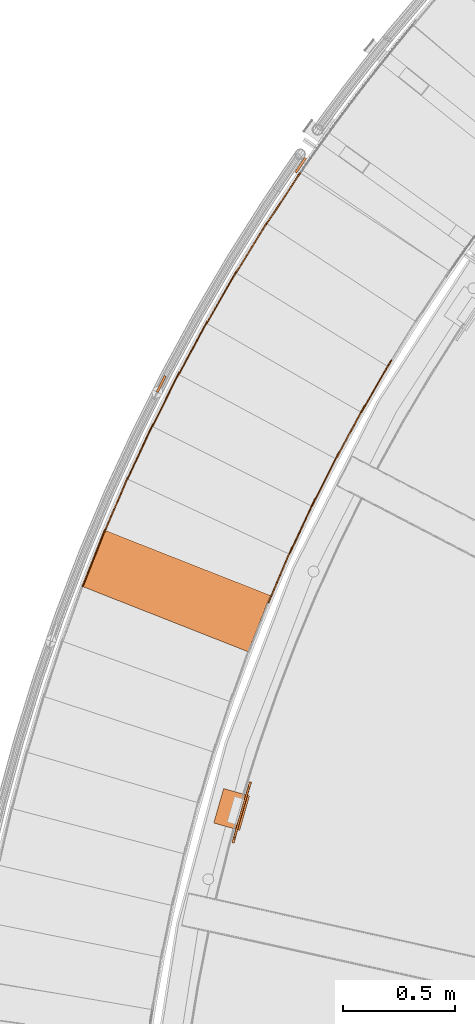
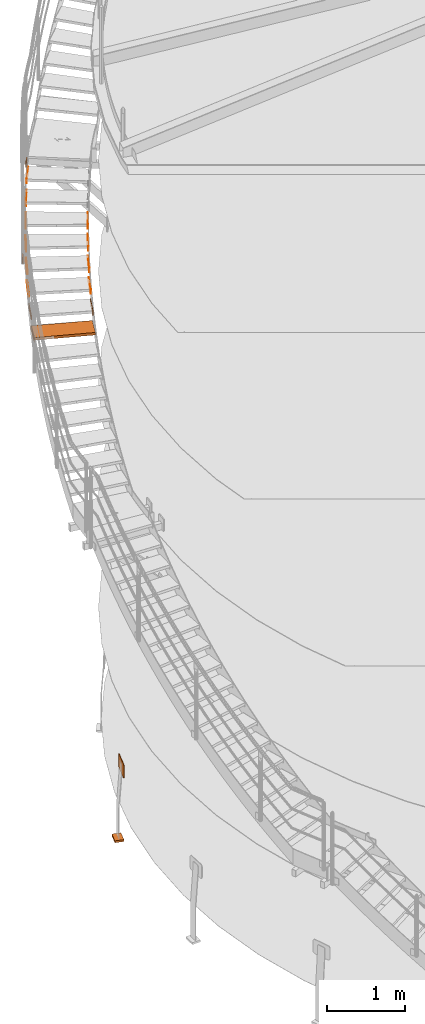
# One storey, part 62 of 126: 18 proxies.
"""IFC2X3 building model written with IfcOpenShell, lengths in millimetres."""

from ifc_helpers import new_model, si_unit, origin, origin_with_axes, place, context, project, spatial, faceted_brep, material, element, save


model = new_model("IFC2X3")

# Units and contexts
context_of_model_1 = context(None, 3, precision=0.1, world=origin())
context_of_model_2 = context(None, 3, precision=0.1, world=origin())
ifc_project = project(units=[si_unit("LENGTHUNIT", "METRE", prefix="MILLI"), si_unit("AREAUNIT", "SQUARE_METRE", prefix="CENTI"), si_unit("VOLUMEUNIT", "CUBIC_METRE", prefix="CENTI"), si_unit("MASSUNIT", "GRAM", prefix="KILO")], contexts=[context_of_model_1, context_of_model_2])

# Site, building, storey
site_placement = place(None, origin_with_axes())
site = spatial("IfcSite", under=ifc_project, at=site_placement, CompositionType="ELEMENT")
building_placement = place(site_placement, origin_with_axes())
building = spatial("IfcBuilding", under=site, at=building_placement, CompositionType="ELEMENT")
storey_placement = place(building_placement, origin_with_axes())
storey = spatial("IfcBuildingStorey", under=building, at=storey_placement, CompositionType="ELEMENT")

# Proxies
ifc_material_1 = material(Name="S235JRG2")
proxy_1_placement = place(storey_placement, origin_with_axes())
element("IfcBuildingElementProxy", 1, at=proxy_1_placement, inside=storey, material=ifc_material_1, context=context_of_model_2, shape_type="Brep", body=[
    faceted_brep([(-220.6481, 11165.666, 6887.93), (-220.6481, 11165.666, 6927.93), (-121.7076, 11416.884, 6927.93), (-121.7076, 11416.884, 6887.93), (514.399, 10876.173, 6887.93), (613.3394, 11127.392, 6887.93), (613.3394, 11127.392, 6927.93), (514.399, 10876.173, 6927.93)], [[[0, 1, 2, 3]], [[4, 5, 6, 7]], [[0, 4, 7, 1]], [[1, 7, 6, 2]], [[2, 6, 5, 3]], [[3, 5, 4, 0]]]),
])
proxy_2_placement = place(storey_placement, origin_with_axes())
element("IfcBuildingElementProxy", 2, at=proxy_2_placement, inside=storey, material=ifc_material_1, context=context_of_model_2, shape_type="Brep", body=[
    faceted_brep([(-225.3003, 11167.498, 6857.93), (-220.6481, 11165.666, 6857.93), (-220.6481, 11165.666, 6927.93), (-225.3003, 11167.498, 6927.93), (-126.3598, 11418.716, 6927.93), (-121.7076, 11416.884, 6927.93), (-121.7076, 11416.884, 6887.93), (-126.3598, 11418.716, 6887.93), (-137.3532, 11390.803, 6857.93), (-132.701, 11388.971, 6857.93)], [[[0, 1, 2, 3]], [[4, 5, 6, 7]], [[0, 8, 9, 1]], [[1, 9, 6, 5, 2]], [[2, 5, 4, 3]], [[0, 3, 4, 7, 8]], [[6, 9, 8, 7]]]),
])
proxy_3_placement = place(storey_placement, origin_with_axes())
element("IfcBuildingElementProxy", 3, at=proxy_3_placement, inside=storey, material=ifc_material_1, context=context_of_model_2, shape_type="Brep", body=[
    faceted_brep([(602.1531, 11095.404, 7031.09), (606.7493, 11093.436, 7031.09), (606.7493, 11093.436, 7101.09), (602.1531, 11095.404, 7101.09), (708.4449, 11343.602, 7101.09), (713.0411, 11341.633, 7101.09), (713.0411, 11341.633, 7061.09), (708.4449, 11343.602, 7061.09), (696.6347, 11316.024, 7031.09), (701.2309, 11314.056, 7031.09)], [[[0, 1, 2, 3]], [[4, 5, 6, 7]], [[0, 8, 9, 1]], [[1, 9, 6, 5, 2]], [[2, 5, 4, 3]], [[0, 3, 4, 7, 8]], [[6, 9, 8, 7]]]),
])
proxy_4_placement = place(storey_placement, origin_with_axes())
element("IfcBuildingElementProxy", 4, at=proxy_4_placement, inside=storey, material=ifc_material_1, context=context_of_model_2, shape_type="Brep", body=[
    faceted_brep([(-128.651, 11408.374, 7031.09), (-124.0547, 11406.406, 7031.09), (-124.0547, 11406.406, 7101.09), (-128.651, 11408.374, 7101.09), (-22.3591, 11656.572, 7101.09), (-17.7629, 11654.603, 7101.09), (-17.7629, 11654.603, 7061.09), (-22.3591, 11656.572, 7061.09), (-34.1693, 11628.994, 7031.09), (-29.5731, 11627.026, 7031.09)], [[[0, 1, 2, 3]], [[4, 5, 6, 7]], [[0, 8, 9, 1]], [[1, 9, 6, 5, 2]], [[2, 5, 4, 3]], [[0, 3, 4, 7, 8]], [[6, 9, 8, 7]]]),
])
proxy_5_placement = place(storey_placement, origin_with_axes())
element("IfcBuildingElementProxy", 5, at=proxy_5_placement, inside=storey, material=ifc_material_1, context=context_of_model_2, shape_type="Brep", body=[
    faceted_brep([(696.3219, 11311.957, 7204.25), (700.8582, 11309.854, 7204.25), (700.8582, 11309.854, 7274.25), (696.3219, 11311.957, 7274.25), (809.873, 11556.918, 7274.25), (814.4093, 11554.816, 7274.25), (814.4093, 11554.816, 7234.25), (809.873, 11556.918, 7234.25), (797.2562, 11529.7, 7204.25), (801.7925, 11527.598, 7204.25)], [[[0, 1, 2, 3]], [[4, 5, 6, 7]], [[0, 8, 9, 1]], [[1, 9, 6, 5, 2]], [[2, 5, 4, 3]], [[0, 3, 4, 7, 8]], [[6, 9, 8, 7]]]),
])
proxy_6_placement = place(storey_placement, origin_with_axes())
element("IfcBuildingElementProxy", 6, at=proxy_6_placement, inside=storey, material=ifc_material_1, context=context_of_model_2, shape_type="Brep", body=[
    faceted_brep([(-24.9537, 11646.302, 7204.25), (-20.4174, 11644.199, 7204.25), (-20.4174, 11644.199, 7274.25), (-24.9537, 11646.302, 7274.25), (88.5974, 11891.263, 7274.25), (93.1337, 11889.16, 7274.25), (93.1337, 11889.16, 7234.25), (88.5974, 11891.263, 7234.25), (75.9806, 11864.045, 7204.25), (80.5169, 11861.942, 7204.25)], [[[0, 1, 2, 3]], [[4, 5, 6, 7]], [[0, 8, 9, 1]], [[1, 9, 6, 5, 2]], [[2, 5, 4, 3]], [[0, 3, 4, 7, 8]], [[6, 9, 8, 7]]]),
])
proxy_7_placement = place(storey_placement, origin_with_axes())
element("IfcBuildingElementProxy", 7, at=proxy_7_placement, inside=storey, material=ifc_material_1, context=context_of_model_2, shape_type="Brep", body=[
    faceted_brep([(796.8238, 11525.644, 7377.41), (801.2963, 11523.409, 7377.41), (801.2963, 11523.409, 7447.41), (796.8238, 11525.644, 7447.41), (917.5358, 11767.157, 7447.41), (922.0083, 11764.922, 7447.41), (922.0083, 11764.922, 7407.41), (917.5358, 11767.157, 7407.41), (904.1234, 11740.323, 7377.41), (908.5958, 11738.087, 7377.41)], [[[0, 1, 2, 3]], [[4, 5, 6, 7]], [[0, 8, 9, 1]], [[1, 9, 6, 5, 2]], [[2, 5, 4, 3]], [[0, 3, 4, 7, 8]], [[6, 9, 8, 7]]]),
])
proxy_8_placement = place(storey_placement, origin_with_axes())
element("IfcBuildingElementProxy", 8, at=proxy_8_placement, inside=storey, material=ifc_material_1, context=context_of_model_2, shape_type="Brep", body=[
    faceted_brep([(85.7017, 11881.074, 7377.41), (90.1741, 11878.839, 7377.41), (90.1741, 11878.839, 7447.41), (85.7017, 11881.074, 7447.41), (206.4137, 12122.587, 7447.41), (210.8861, 12120.352, 7447.41), (210.8861, 12120.352, 7407.41), (206.4137, 12122.587, 7407.41), (193.0012, 12095.752, 7377.41), (197.4737, 12093.517, 7377.41)], [[[0, 1, 2, 3]], [[4, 5, 6, 7]], [[0, 8, 9, 1]], [[1, 9, 6, 5, 2]], [[2, 5, 4, 3]], [[0, 3, 4, 7, 8]], [[6, 9, 8, 7]]]),
])
proxy_9_placement = place(storey_placement, origin_with_axes())
element("IfcBuildingElementProxy", 9, at=proxy_9_placement, inside=storey, material=ifc_material_1, context=context_of_model_2, shape_type="Brep", body=[
    faceted_brep([(903.5718, 11736.281, 7550.57), (907.9765, 11733.915, 7550.57), (907.9765, 11733.915, 7620.57), (903.5718, 11736.281, 7620.57), (1031.34, 11974.136, 7620.57), (1035.7448, 11971.77, 7620.57), (1035.7448, 11971.77, 7580.57), (1031.34, 11974.136, 7580.57), (1017.1436, 11947.708, 7550.57), (1021.5483, 11945.342, 7550.57)], [[[0, 1, 2, 3]], [[4, 5, 6, 7]], [[0, 8, 9, 1]], [[1, 9, 6, 5, 2]], [[2, 5, 4, 3]], [[0, 3, 4, 7, 8]], [[6, 9, 8, 7]]]),
])
proxy_10_placement = place(storey_placement, origin_with_axes())
element("IfcBuildingElementProxy", 10, at=proxy_10_placement, inside=storey, material=ifc_material_1, context=context_of_model_2, shape_type="Brep", body=[
    faceted_brep([(203.2193, 12112.487, 7550.57), (207.624, 12110.121, 7550.57), (207.624, 12110.121, 7620.57), (203.2193, 12112.487, 7620.57), (330.9876, 12350.343, 7620.57), (335.3923, 12347.977, 7620.57), (335.3923, 12347.977, 7580.57), (330.9876, 12350.343, 7580.57), (316.7911, 12323.915, 7550.57), (321.1958, 12321.548, 7550.57)], [[[0, 1, 2, 3]], [[4, 5, 6, 7]], [[0, 8, 9, 1]], [[1, 9, 6, 5, 2]], [[2, 5, 4, 3]], [[0, 3, 4, 7, 8]], [[6, 9, 8, 7]]]),
])
proxy_11_placement = place(storey_placement, origin_with_axes())
element("IfcBuildingElementProxy", 11, at=proxy_11_placement, inside=storey, material=ifc_material_1, context=context_of_model_2, shape_type="Brep", body=[
    faceted_brep([(1016.4733, 11943.684, 7723.73), (1020.8064, 11941.19, 7723.73), (1020.8064, 11941.19, 7793.73), (1016.4733, 11943.684, 7793.73), (1151.1871, 12177.676, 7793.73), (1155.5203, 12175.181, 7793.73), (1155.5203, 12175.181, 7753.73), (1151.1871, 12177.676, 7753.73), (1136.2189, 12151.677, 7723.73), (1140.5521, 12149.182, 7723.73)], [[[0, 1, 2, 3]], [[4, 5, 6, 7]], [[0, 8, 9, 1]], [[1, 9, 6, 5, 2]], [[2, 5, 4, 3]], [[0, 3, 4, 7, 8]], [[6, 9, 8, 7]]]),
])
proxy_12_placement = place(storey_placement, origin_with_axes())
element("IfcBuildingElementProxy", 12, at=proxy_12_placement, inside=storey, material=ifc_material_1, context=context_of_model_2, shape_type="Brep", body=[
    faceted_brep([(327.4973, 12340.342, 7723.73), (331.8305, 12337.847, 7723.73), (331.8305, 12337.847, 7793.73), (327.4973, 12340.342, 7793.73), (462.2111, 12574.333, 7793.73), (466.5443, 12571.839, 7793.73), (466.5443, 12571.839, 7753.73), (462.2111, 12574.333, 7753.73), (447.2429, 12548.334, 7723.73), (451.5761, 12545.84, 7723.73)], [[[0, 1, 2, 3]], [[4, 5, 6, 7]], [[0, 8, 9, 1]], [[1, 9, 6, 5, 2]], [[2, 5, 4, 3]], [[0, 3, 4, 7, 8]], [[6, 9, 8, 7]]]),
])
proxy_13_placement = place(storey_placement, origin_with_axes())
element("IfcBuildingElementProxy", 13, at=proxy_13_placement, inside=storey, material=ifc_material_1, context=context_of_model_2, shape_type="Brep", body=[
    faceted_brep([(458.428, 12564.439, 7896.89), (462.6859, 12561.818, 7896.89), (462.6859, 12561.818, 7966.89), (458.428, 12564.439, 7966.89), (599.9707, 12794.365, 7966.89), (604.2286, 12791.743, 7966.89), (604.2286, 12791.743, 7926.89), (599.9707, 12794.365, 7926.89), (584.2437, 12768.817, 7896.89), (588.5016, 12766.196, 7896.89)], [[[0, 1, 2, 3]], [[4, 5, 6, 7]], [[0, 8, 9, 1]], [[1, 9, 6, 5, 2]], [[2, 5, 4, 3]], [[0, 3, 4, 7, 8]], [[6, 9, 8, 7]]]),
])
proxy_14_placement = place(storey_placement, origin_with_axes())
element("IfcBuildingElementProxy", 14, at=proxy_14_placement, inside=storey, material=ifc_material_1, context=context_of_model_2, shape_type="Brep", body=[
    faceted_brep([(595.898, 12784.586, 8070.05), (600.0769, 12781.841, 8070.05), (600.0769, 12781.841, 8140.05), (595.898, 12784.586, 8140.05), (744.1468, 13010.246, 8140.05), (748.3257, 13007.5, 8140.05), (748.3257, 13007.5, 8100.05), (744.1468, 13010.246, 8100.05), (727.6747, 12985.172, 8070.05), (731.8536, 12982.427, 8070.05)], [[[0, 1, 2, 3]], [[4, 5, 6, 7]], [[0, 8, 9, 1]], [[1, 9, 6, 5, 2]], [[2, 5, 4, 3]], [[0, 3, 4, 7, 8]], [[6, 9, 8, 7]]]),
])
ifc_material_2 = material(Name="STAHL")
proxy_15_placement = place(storey_placement, origin_with_axes())
element("IfcBuildingElementProxy", 15, at=proxy_15_placement, inside=storey, material=ifc_material_2, Name="profile", context=context_of_model_2, shape_type="Brep", body=[
    faceted_brep([(525.1, 10282.0, 704.7), (526.3, 10286.0, 701.2), (518.7, 10288.4, 701.2), (517.3, 10283.9, 705.0), (523.6, 10277.2, 707.5), (515.7, 10278.6, 707.9), (521.9, 10271.5, 709.4), (514.1, 10273.3, 709.5), (458.1, 10048.8, 709.5), (459.5, 10054.1, 710.0), (479.1, 10124.9, 710.0), (499.3, 10195.4, 710.0), (520.2, 10265.7, 710.0), (512.5, 10268.1, 710.0), (491.6, 10197.6, 710.0), (471.4, 10127.0, 710.0), (451.8, 10056.2, 710.0), (450.2, 10050.4, 709.4), (453.1, 10030.3, 697.0), (454.0, 10033.7, 701.2), (446.2, 10035.7, 701.2), (445.3, 10032.0, 696.5), (452.3, 10027.6, 692.0), (444.5, 10029.3, 691.0), (451.9, 10025.8, 686.0), (444.1, 10027.7, 685.5), (451.7, 10025.2, 680.0), (444.0, 10027.2, 680.0), (444.0, 10027.2, 520.0), (444.1, 10027.8, 514.0), (451.8, 10025.7, 514.5), (451.7, 10025.2, 520.0), (517.4, 10284.3, 495.3), (518.7, 10288.4, 498.8), (526.3, 10286.0, 498.8), (525.0, 10281.5, 495.0), (516.0, 10279.5, 492.5), (523.4, 10276.2, 492.1), (514.3, 10273.8, 490.6), (521.8, 10271.0, 490.5), (457.9, 10048.3, 490.6), (450.3, 10050.9, 490.5), (451.8, 10056.2, 490.0), (471.4, 10127.0, 490.0), (491.6, 10197.6, 490.0), (512.5, 10268.1, 490.0), (520.2, 10265.7, 490.0), (499.3, 10195.4, 490.0), (479.1, 10124.9, 490.0), (459.5, 10054.1, 490.0), (445.3, 10032.3, 503.0), (446.2, 10035.7, 498.8), (454.0, 10033.7, 498.8), (453.0, 10030.0, 503.5), (444.6, 10029.7, 508.0), (452.2, 10027.2, 509.0), (448.9, 10045.6, 492.1), (456.4, 10042.6, 492.5), (447.5, 10040.3, 495.0), (455.1, 10037.8, 495.3), (528.7, 10293.8, 514.0), (521.1, 10296.3, 514.5), (521.3, 10296.8, 520.0), (521.3, 10296.8, 680.0), (521.1, 10296.2, 686.0), (528.8, 10293.9, 685.5), (528.9, 10294.4, 680.0), (528.9, 10294.4, 520.0), (520.6, 10294.8, 509.0), (528.2, 10292.0, 508.0), (519.8, 10292.0, 503.5), (527.4, 10289.4, 503.0), (456.6, 10043.5, 707.9), (448.6, 10044.7, 707.5), (455.2, 10038.2, 705.0), (447.4, 10039.8, 704.7), (528.3, 10292.4, 691.0), (520.5, 10294.4, 692.0), (527.5, 10289.7, 696.5), (519.7, 10291.8, 697.0)], [[[0, 1, 2, 3]], [[4, 0, 3, 5]], [[6, 4, 5, 7]], [[8, 9, 10, 11, 12, 6, 7, 13, 14, 15, 16, 17]], [[18, 19, 20, 21]], [[22, 18, 21, 23]], [[24, 22, 23, 25]], [[26, 24, 25, 27, 28, 29, 30, 31]], [[32, 33, 34, 35]], [[36, 32, 35, 37]], [[38, 36, 37, 39]], [[40, 41, 42, 43, 44, 45, 38, 39, 46, 47, 48, 49]], [[50, 51, 52, 53]], [[54, 50, 53, 55]], [[29, 54, 55, 30]], [[56, 41, 40, 57]], [[58, 56, 57, 59]], [[51, 58, 59, 52]], [[60, 61, 62, 63, 64, 65, 66, 67]], [[68, 61, 60, 69]], [[70, 68, 69, 71]], [[33, 70, 71, 34]], [[72, 8, 17, 73]], [[74, 72, 73, 75]], [[19, 74, 75, 20]], [[76, 65, 64, 77]], [[78, 76, 77, 79]], [[1, 78, 79, 2]], [[26, 31, 30, 55, 53, 52, 59, 57, 40, 49, 48, 47, 46, 39, 37, 35, 34, 71, 69, 60, 67, 66, 65, 76, 78, 1, 0, 4, 6, 12, 11, 10, 9, 8, 72, 74, 19, 18, 22, 24]], [[28, 27, 25, 23, 21, 20, 75, 73, 17, 16, 15, 14, 13, 7, 5, 3, 2, 79, 77, 64, 63, 62, 61, 68, 70, 33, 32, 36, 38, 45, 44, 43, 42, 41, 56, 58, 51, 50, 54, 29]]]),
])
proxy_16_placement = place(storey_placement, origin_with_axes())
element("IfcBuildingElementProxy", 16, at=proxy_16_placement, inside=storey, material=ifc_material_2, Name="profile", context=context_of_model_2, shape_type="Brep", body=[
    faceted_brep([(476.7, 10080.5, -530.0), (361.3, 10113.6, -530.0), (405.4, 10267.4, -530.0), (520.8, 10234.3, -530.0), (361.3, 10113.6, -500.0), (405.4, 10267.4, -500.0), (476.7, 10080.5, -500.0), (520.8, 10234.3, -500.0)], [[[0, 1, 2, 3]], [[1, 4, 5, 2]], [[4, 6, 7, 5]], [[6, 0, 3, 7]], [[1, 0, 6, 4]], [[7, 3, 2, 5]]]),
])
proxy_17_placement = place(storey_placement, origin_with_axes())
element("IfcBuildingElementProxy", 17, at=proxy_17_placement, inside=storey, material=ifc_material_1, context=context_of_model_2, shape_type="Brep", body=[
    faceted_brep([(766.8944, 13079.136, 8142.65), (775.1634, 13073.513, 8142.65), (730.1749, 13007.361, 8142.65), (721.906, 13012.985, 8142.65), (766.8944, 13079.136, 8242.65), (721.906, 13012.985, 8242.65), (730.1749, 13007.361, 8242.65), (775.1634, 13073.513, 8242.65)], [[[0, 1, 2, 3]], [[4, 5, 6, 7]], [[0, 4, 7, 1]], [[1, 7, 6, 2]], [[0, 3, 5, 4]], [[2, 6, 5, 3]]]),
])
proxy_18_placement = place(storey_placement, origin_with_axes())
element("IfcBuildingElementProxy", 18, at=proxy_18_placement, inside=storey, material=ifc_material_1, Name="HANDLAUF", context=context_of_model_2, shape_type="Brep", body=[
    faceted_brep([(141.4097, 12106.559, 7444.7208), (150.3511, 12102.081, 7444.7208), (114.5291, 12030.55, 7444.7208), (105.5876, 12035.028, 7444.7208), (141.4097, 12106.559, 7544.7208), (105.5876, 12035.028, 7544.7208), (114.5291, 12030.55, 7544.7208), (150.3511, 12102.081, 7544.7208)], [[[0, 1, 2, 3]], [[4, 5, 6, 7]], [[0, 4, 7, 1]], [[1, 7, 6, 2]], [[2, 6, 5, 3]], [[3, 5, 4, 0]]]),
])

save(model, "model.ifc")
